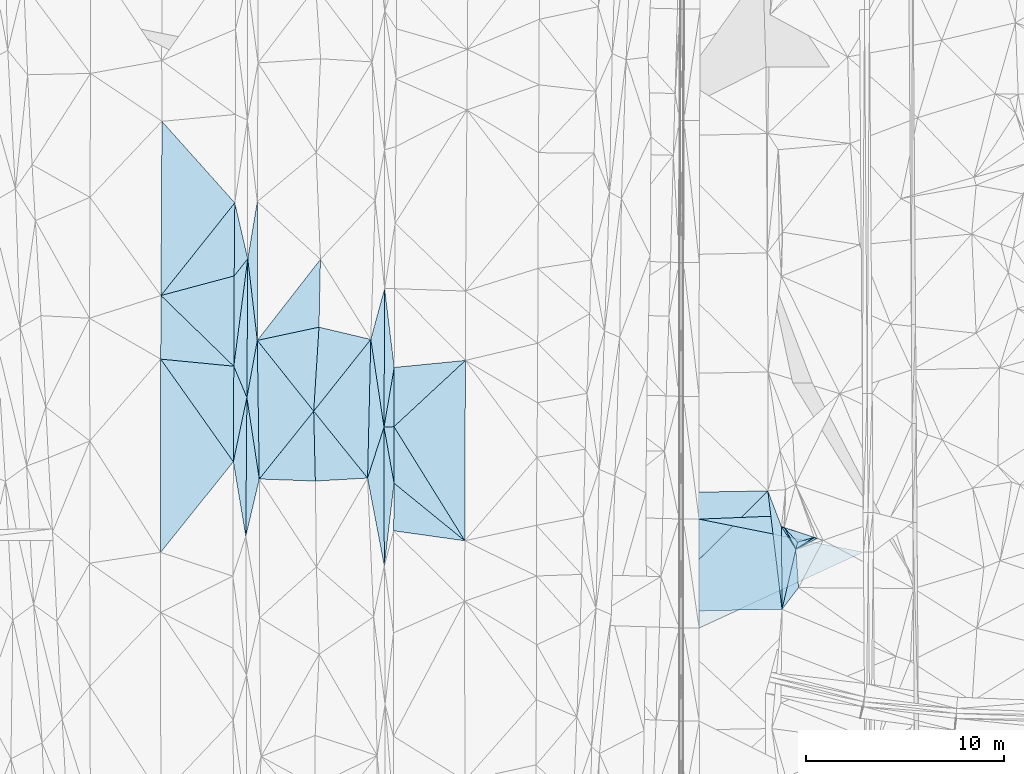
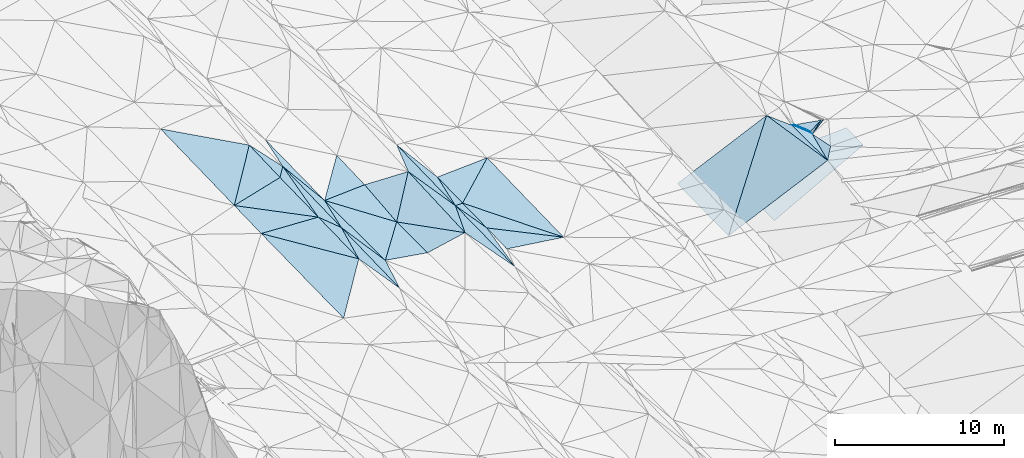
# One storey, part 111 of 275: 45 plates.
"""IFC2X3 building model written with IfcOpenShell, lengths in millimetres."""

from ifc_helpers import new_model, si_unit, frame, origin_with_axes, place, context, subcontext, project, spatial, polyline, outline, extrude, material, type_object, element, save


model = new_model("IFC2X3")

# Units and contexts
model_context = context("Model", 3, precision=1e-05, world=origin_with_axes())
body_context = subcontext(model_context, "Body", "Model", "MODEL_VIEW")
ifc_project = project(units=[si_unit("LENGTHUNIT", "METRE", prefix="MILLI"), si_unit("AREAUNIT", "SQUARE_METRE"), si_unit("VOLUMEUNIT", "CUBIC_METRE"), si_unit("MASSUNIT", "GRAM", prefix="KILO"), si_unit("TIMEUNIT", "SECOND"), si_unit("PLANEANGLEUNIT", "RADIAN"), si_unit("SOLIDANGLEUNIT", "STERADIAN"), si_unit("THERMODYNAMICTEMPERATUREUNIT", "DEGREE_CELSIUS"), si_unit("LUMINOUSINTENSITYUNIT", "LUMEN")], contexts=[model_context])

# Site, building, storey
site_placement = place(None, origin_with_axes())
site = spatial("IfcSite", under=ifc_project, at=site_placement, CompositionType="ELEMENT")
building_placement = place(site_placement, origin_with_axes())
building = spatial("IfcBuilding", under=site, at=building_placement, Name="Undefined", CompositionType="ELEMENT")
storey_placement = place(building_placement, origin_with_axes())
storey = spatial("IfcBuildingStorey", under=building, at=storey_placement, Name="Undefined", CompositionType="ELEMENT", Elevation=0.0)

# Plates
ifc_material = material()
plate_type_1 = type_object("IfcPlateType", PredefinedType="NOTDEFINED")
plate_1_placement = place(storey_placement, frame((-76061.398621355, 88579.0431568378, 42826.5059365484), z_axis=(0.153650073326919, -0.00552550848150955, -0.988109874316947), x_axis=(0.0631321634469689, 0.997996184661326, 0.00423619403960211)))
element("IfcPlate", 1, at=plate_1_placement, inside=storey, type_object=plate_type_1, material=ifc_material, Name="00", context=body_context, shape_type="SweptSolid", body=[
    extrude(outline(polyline([(0.0, 0.0), (4249.0966796875, 8.78935679793358e-09), (3798.419921875, 2680.11206054688), (0.0, 0.0)])), frame((-8.85201319254618e-08, 2.18876761149539e-07, -0.5000001331573), z_axis=(0.0, 0.0, 1.0), x_axis=(1.0, 0.0, 0.0)), (0.0, 0.0, 1.0), 1.0),
])
plate_type_2 = type_object("IfcPlateType", PredefinedType="NOTDEFINED")
plate_2_placement = place(storey_placement, frame((-48329.8620657515, 83465.6742146861, 43014.8511874444), z_axis=(0.0200807678010554, 0.0185787536200266, -0.999625726298822), x_axis=(0.0071784820166339, -0.999804238047834, -0.0184378680309524)))
element("IfcPlate", 2, at=plate_2_placement, inside=storey, type_object=plate_type_2, material=ifc_material, Name="00_PR", context=body_context, shape_type="SweptSolid", body=[
    extrude(outline(polyline([(0.0, 0.0), (2000.33972167969, 1.37588358484209e-08), (279.071472167969, 8286.1865234375), (0.0, 0.0)])), frame((-8.85201319254618e-08, 2.18876761149539e-07, -0.5000001331573), z_axis=(0.0, 0.0, 1.0), x_axis=(1.0, 0.0, 0.0)), (0.0, 0.0, 1.0), 1.0),
])
plate_type_3 = type_object("IfcPlateType", PredefinedType="NOTDEFINED")
plate_3_placement = place(storey_placement, frame((-56608.96006022, 77631.715382958, 42743.7001808371), z_axis=(0.0199500962876744, 0.0179262548293264, -0.999640256815374), x_axis=(-0.000581992991861325, 0.9998392866212, 0.0179182089776776)))
element("IfcPlate", 3, at=plate_3_placement, inside=storey, type_object=plate_type_3, material=ifc_material, Name="00_PR", context=body_context, shape_type="SweptSolid", body=[
    extrude(outline(polyline([(0.0, 0.0), (5499.43359375, -1.13941496238112e-08), (3832.76513671875, 8297.3408203125), (0.0, 0.0)])), frame((-8.85201319254618e-08, 2.18876761149539e-07, -0.5000001331573), z_axis=(0.0, 0.0, 1.0), x_axis=(1.0, 0.0, 0.0)), (0.0, 0.0, 1.0), 1.0),
])
plate_type_4 = type_object("IfcPlateType", PredefinedType="NOTDEFINED")
plate_4_placement = place(storey_placement, frame((-79389.4975679414, 96270.150412812, 43334.5002580193), z_axis=(0.026293548005733, 0.0196296631215967, -0.999461517847987), x_axis=(-0.128722748368799, -0.991417148651079, -0.022858071067959)))
element("IfcPlate", 4, at=plate_4_placement, inside=storey, type_object=plate_type_4, material=ifc_material, Name="00", context=body_context, shape_type="SweptSolid", body=[
    extrude(outline(polyline([(0.0, 0.0), (5468.52783203125, -1.86992110684514e-08), (946.277893066406, 567.939392089844), (0.0, 0.0)])), frame((-8.85201319254618e-08, 2.18876761149539e-07, -0.5000001331573), z_axis=(0.0, 0.0, 1.0), x_axis=(1.0, 0.0, 0.0)), (0.0, 0.0, 1.0), 1.0),
])
plate_type_5 = type_object("IfcPlateType", PredefinedType="NOTDEFINED")
plate_5_placement = place(storey_placement, frame((-83783.5033080834, 91207.1132388695, 43099.500396401), z_axis=(0.0356257678011647, 0.0194384997804789, -0.999176135320926), x_axis=(0.577873647541233, -0.816112554836854, 0.00472708314451159)))
element("IfcPlate", 5, at=plate_5_placement, inside=storey, type_object=plate_type_5, material=ifc_material, Name="00", context=body_context, shape_type="SweptSolid", body=[
    extrude(outline(polyline([(0.0, 0.0), (6346.408203125, 4.25570760853589e-08), (7957.20947265625, 5646.93017578125), (0.0, 0.0)])), frame((-8.85201319254618e-08, 2.18876761149539e-07, -0.5000001331573), z_axis=(0.0, 0.0, 1.0), x_axis=(1.0, 0.0, 0.0)), (0.0, 0.0, 1.0), 1.0),
])
plate_type_6 = type_object("IfcPlateType", PredefinedType="NOTDEFINED")
plate_6_placement = place(storey_placement, frame((-72005.5982954717, 84944.676149146, 43179.5001190756), z_axis=(-0.00897304242037606, 0.0210203564641131, -0.999738780444094), x_axis=(-0.176306046624745, 0.984083362593124, 0.0222736030081294)))
element("IfcPlate", 6, at=plate_6_placement, inside=storey, type_object=plate_type_6, material=ifc_material, Name="00", context=body_context, shape_type="SweptSolid", body=[
    extrude(outline(polyline([(0.0, 0.0), (2873.3564453125, 5.33327693119645e-09), (2808.68383789063, 499.494232177734), (0.0, 0.0)])), frame((-8.85201319254618e-08, 2.18876761149539e-07, -0.5000001331573), z_axis=(0.0, 0.0, 1.0), x_axis=(1.0, 0.0, 0.0)), (0.0, 0.0, 1.0), 1.0),
])
plate_type_7 = type_object("IfcPlateType", PredefinedType="NOTDEFINED")
plate_7_placement = place(storey_placement, frame((-76061.5406169814, 88579.0596890403, 42826.5044470904), z_axis=(-0.130337919078781, 0.0275417415568126, -0.991087019046376), x_axis=(0.0236364985596356, -0.999243682087104, -0.0308768480393752)))
element("IfcPlate", 7, at=plate_7_placement, inside=storey, type_object=plate_type_7, material=ifc_material, Name="00", context=body_context, shape_type="SweptSolid", body=[
    extrude(outline(polyline([(0.0, 0.0), (3530.15307617188, -7.37782102078199e-09), (3348.0322265625, 2850.384765625), (0.0, 0.0)])), frame((-8.85201319254618e-08, 2.18876761149539e-07, -0.5000001331573), z_axis=(0.0, 0.0, 1.0), x_axis=(1.0, 0.0, 0.0)), (0.0, 0.0, 1.0), 1.0),
])
plate_type_8 = type_object("IfcPlateType", PredefinedType="NOTDEFINED")
plate_8_placement = place(storey_placement, frame((-79389.5046928364, 96270.1513398641, 43334.5001404173), z_axis=(0.012046184697125, 0.0214849200903048, -0.999696597795029), x_axis=(-0.00623975140575909, -0.999748058038055, -0.0215612140551691)))
element("IfcPlate", 8, at=plate_8_placement, inside=storey, type_object=plate_type_8, material=ifc_material, Name="00", context=body_context, shape_type="SweptSolid", body=[
    extrude(outline(polyline([(0.0, 0.0), (7003.31640625, 3.29746399074793e-08), (5427.31396484375, 670.120544433594), (0.0, 0.0)])), frame((-8.85201319254618e-08, 2.18876761149539e-07, -0.5000001331573), z_axis=(0.0, 0.0, 1.0), x_axis=(1.0, 0.0, 0.0)), (0.0, 0.0, 1.0), 1.0),
])
plate_type_9 = type_object("IfcPlateType", PredefinedType="NOTDEFINED")
plate_9_placement = place(storey_placement, frame((-79433.2104893213, 89268.5973148834, 43183.5000613319), z_axis=(-0.00164496206152359, 0.0170063789564354, -0.999854027933381), x_axis=(-0.00764668241078133, -0.999826362449791, -0.0169933280592088)))
element("IfcPlate", 9, at=plate_9_placement, inside=storey, type_object=plate_type_9, material=ifc_material, Name="00", context=body_context, shape_type="SweptSolid", body=[
    extrude(outline(polyline([(0.0, 0.0), (7002.74853515625, 4.64642653241754e-08), (3246.44555664063, 658.084838867188), (0.0, 0.0)])), frame((-8.85201319254618e-08, 2.18876761149539e-07, -0.5000001331573), z_axis=(0.0, 0.0, 1.0), x_axis=(1.0, 0.0, 0.0)), (0.0, 0.0, 1.0), 1.0),
])
plate_type_10 = type_object("IfcPlateType", PredefinedType="NOTDEFINED")
plate_10_placement = place(storey_placement, frame((-51723.1854800835, 81604.5571297598, 44869.5162257406), z_axis=(-0.252757597405003, -0.000325343953163526, -0.967529581514365), x_axis=(-0.225145569483551, -0.972528379441403, 0.0591440928834538)))
element("IfcPlate", 10, at=plate_10_placement, inside=storey, type_object=plate_type_10, material=ifc_material, Name="00", context=body_context, shape_type="SweptSolid", body=[
    extrude(outline(polyline([(0.0, 0.0), (3111.04614257813, -1.9674189388752e-08), (-946.832641601563, 1001.05340576172), (0.0, 0.0)])), frame((-8.85201319254618e-08, 2.18876761149539e-07, -0.5000001331573), z_axis=(0.0, 0.0, 1.0), x_axis=(1.0, 0.0, 0.0)), (0.0, 0.0, 1.0), 1.0),
])
plate_type_11 = type_object("IfcPlateType", PredefinedType="NOTDEFINED")
plate_11_placement = place(storey_placement, frame((-80093.4344875476, 90848.5565903541, 43209.5000570496), z_axis=(0.000327801689314104, 0.0165908321142713, -0.99986230893849), x_axis=(0.385520432609089, -0.92257438894118, -0.0151819929755038)))
element("IfcPlate", 11, at=plate_11_placement, inside=storey, type_object=plate_type_11, material=ifc_material, Name="00", context=body_context, shape_type="SweptSolid", body=[
    extrude(outline(polyline([(0.0, 0.0), (1712.55505371094, -8.93487595021725e-09), (4440.0498046875, 1879.69616699219), (0.0, 0.0)])), frame((-8.85201319254618e-08, 2.18876761149539e-07, -0.5000001331573), z_axis=(0.0, 0.0, 1.0), x_axis=(1.0, 0.0, 0.0)), (0.0, 0.0, 1.0), 1.0),
])
plate_type_12 = type_object("IfcPlateType", PredefinedType="NOTDEFINED")
plate_12_placement = place(storey_placement, frame((-73342.2632609968, 85203.2659626728, 43148.5013560587), z_axis=(0.0726297184403839, 0.0134095323184575, -0.997268824561497), x_axis=(0.0233562374517354, 0.999612527194022, 0.0151420490316935)))
element("IfcPlate", 12, at=plate_12_placement, inside=storey, type_object=plate_type_12, material=ifc_material, Name="00", context=body_context, shape_type="SweptSolid", body=[
    extrude(outline(polyline([(0.0, 0.0), (7000.37353515625, 1.82772055268288e-08), (2588.86010742188, 771.899353027344), (0.0, 0.0)])), frame((-8.85201319254618e-08, 2.18876761149539e-07, -0.5000001331573), z_axis=(0.0, 0.0, 1.0), x_axis=(1.0, 0.0, 0.0)), (0.0, 0.0, 1.0), 1.0),
])
plate_type_13 = type_object("IfcPlateType", PredefinedType="NOTDEFINED")
plate_13_placement = place(storey_placement, frame((-51723.0053609567, 81604.716422007, 44869.5290448831), z_axis=(0.107479046016007, 0.31825643927385, -0.941892294016794), x_axis=(0.80539851184155, 0.527581462608026, 0.270168535243823)))
element("IfcPlate", 13, at=plate_13_placement, inside=storey, type_object=plate_type_13, material=ifc_material, Name="00", context=body_context, shape_type="SweptSolid", body=[
    extrude(outline(polyline([(0.0, 0.0), (1147.43188476563, 1.55705492943525e-09), (1244.16967773438, 130.926712036133), (0.0, 0.0)])), frame((-8.85201319254618e-08, 2.18876761149539e-07, -0.5000001331573), z_axis=(0.0, 0.0, 1.0), x_axis=(1.0, 0.0, 0.0)), (0.0, 0.0, 1.0), 1.0),
])
plate_type_14 = type_object("IfcPlateType", PredefinedType="NOTDEFINED")
plate_14_placement = place(storey_placement, frame((-50798.8081342325, 82210.1724704172, 45179.5822710436), z_axis=(0.222020974117627, 0.502739541150144, -0.835439788863328), x_axis=(-0.885869510351093, -0.253963555388073, -0.388249562993913)))
element("IfcPlate", 14, at=plate_14_placement, inside=storey, type_object=plate_type_14, material=ifc_material, Name="00", context=body_context, shape_type="SweptSolid", body=[
    extrude(outline(polyline([(0.0, 0.0), (952.995300292969, -1.29512045532465e-09), (1250.79321289063, 991.370971679688), (0.0, 0.0)])), frame((-8.85201319254618e-08, 2.18876761149539e-07, -0.5000001331573), z_axis=(0.0, 0.0, 1.0), x_axis=(1.0, 0.0, 0.0)), (0.0, 0.0, 1.0), 1.0),
])
plate_type_15 = type_object("IfcPlateType", PredefinedType="NOTDEFINED")
plate_15_placement = place(storey_placement, frame((-51722.9437625715, 81604.7063984948, 44869.5368877459), z_axis=(0.23067761607835, 0.298213137673759, -0.926205572191822), x_axis=(-0.528911314443468, 0.837400030525068, 0.137891298965157)))
element("IfcPlate", 15, at=plate_15_placement, inside=storey, type_object=plate_type_15, material=ifc_material, Name="00", context=body_context, shape_type="SweptSolid", body=[
    extrude(outline(polyline([(0.0, 0.0), (1377.89697265625, -9.69521352089942e-10), (1266.71301269531, 100.688301086426), (0.0, 0.0)])), frame((-8.85201319254618e-08, 2.18876761149539e-07, -0.5000001331573), z_axis=(0.0, 0.0, 1.0), x_axis=(1.0, 0.0, 0.0)), (0.0, 0.0, 1.0), 1.0),
])
plate_type_16 = type_object("IfcPlateType", PredefinedType="NOTDEFINED")
plate_16_placement = place(storey_placement, frame((-72512.1295597054, 87772.2972753549, 43243.5030427005), z_axis=(0.108695149794578, 0.018829851161569, -0.99389677588589), x_axis=(-0.148846257491416, 0.988857299567939, 0.00245616001151394)))
element("IfcPlate", 16, at=plate_16_placement, inside=storey, type_object=plate_type_16, material=ifc_material, Name="00", context=body_context, shape_type="SweptSolid", body=[
    extrude(outline(polyline([(0.0, 0.0), (4478.53564453125, -8.30914359539747e-09), (6914.90185546875, 1079.14953613281), (0.0, 0.0)])), frame((-8.85201319254618e-08, 2.18876761149539e-07, -0.5000001331573), z_axis=(0.0, 0.0, 1.0), x_axis=(1.0, 0.0, 0.0)), (0.0, 0.0, 1.0), 1.0),
])
plate_type_17 = type_object("IfcPlateType", PredefinedType="NOTDEFINED")
plate_17_placement = place(storey_placement, frame((-79486.7734866413, 82267.0649761344, 43064.500320727), z_axis=(-0.0320753015141071, 0.0172303216631153, -0.999336925690312), x_axis=(0.00764668246942341, 0.999826362449911, 0.016993328025735)))
element("IfcPlate", 17, at=plate_17_placement, inside=storey, type_object=plate_type_17, material=ifc_material, Name="00", context=body_context, shape_type="SweptSolid", body=[
    extrude(outline(polyline([(0.0, 0.0), (7002.74853515625, 4.64642653241754e-08), (2893.41333007813, 657.383361816406), (0.0, 0.0)])), frame((-8.85201319254618e-08, 2.18876761149539e-07, -0.5000001331573), z_axis=(0.0, 0.0, 1.0), x_axis=(1.0, 0.0, 0.0)), (0.0, 0.0, 1.0), 1.0),
])
plate_type_18 = type_object("IfcPlateType", PredefinedType="NOTDEFINED")
plate_18_placement = place(storey_placement, frame((-68436.269946508, 82039.8649116986, 43019.500291198), z_axis=(-0.0276908734220919, 0.0210220872404197, -0.99939546095486), x_axis=(-0.989922918560391, 0.138319287382846, 0.0303379308256113)))
element("IfcPlate", 18, at=plate_18_placement, inside=storey, type_object=plate_type_18, material=ifc_material, Name="00", context=body_context, shape_type="SweptSolid", body=[
    extrude(outline(polyline([(0.0, 0.0), (3625.82397460938, 5.34055288881063e-09), (3940.0146484375, 2383.27172851563), (0.0, 0.0)])), frame((-8.85201319254618e-08, 2.18876761149539e-07, -0.5000001331573), z_axis=(0.0, 0.0, 1.0), x_axis=(1.0, 0.0, 0.0)), (0.0, 0.0, 1.0), 1.0),
])
plate_type_19 = type_object("IfcPlateType", PredefinedType="NOTDEFINED")
plate_19_placement = place(storey_placement, frame((-68436.269946508, 82039.8649116986, 43019.500291198), z_axis=(-0.0277170835757687, 0.0209898774193891, -0.999395411398298), x_axis=(-0.775142973463073, 0.630829639659116, 0.0347467468747148)))
element("IfcPlate", 19, at=plate_19_placement, inside=storey, type_object=plate_type_19, material=ifc_material, Name="00", context=body_context, shape_type="SweptSolid", body=[
    extrude(outline(polyline([(0.0, 0.0), (4604.74755859375, 2.76450009550899e-08), (6408.77685546875, 2209.90454101563), (0.0, 0.0)])), frame((-8.85201319254618e-08, 2.18876761149539e-07, -0.5000001331573), z_axis=(0.0, 0.0, 1.0), x_axis=(1.0, 0.0, 0.0)), (0.0, 0.0, 1.0), 1.0),
])
plate_type_20 = type_object("IfcPlateType", PredefinedType="NOTDEFINED")
plate_20_placement = place(storey_placement, frame((-52311.016542431, 82711.397692289, 45079.5486156422), z_axis=(-0.426603078991157, -0.0552514056152115, -0.902749741164631), x_axis=(0.644994158429637, -0.718294557505941, -0.260836086937733)))
element("IfcPlate", 20, at=plate_20_placement, inside=storey, type_object=plate_type_20, material=ifc_material, Name="00", context=body_context, shape_type="SweptSolid", body=[
    extrude(outline(polyline([(0.0, 0.0), (1035.1328125, -4.8712536226958e-09), (1228.92443847656, 323.179260253906), (0.0, 0.0)])), frame((-8.85201319254618e-08, 2.18876761149539e-07, -0.5000001331573), z_axis=(0.0, 0.0, 1.0), x_axis=(1.0, 0.0, 0.0)), (0.0, 0.0, 1.0), 1.0),
])
plate_type_21 = type_object("IfcPlateType", PredefinedType="NOTDEFINED")
plate_21_placement = place(storey_placement, frame((-79389.5004629837, 96270.1527140369, 43334.5002371914), z_axis=(0.0205020702365341, 0.0242175538929406, -0.999496460823878), x_axis=(-0.620520093969136, -0.78354901782711, -0.0317135561346526)))
element("IfcPlate", 21, at=plate_21_placement, inside=storey, type_object=plate_type_21, material=ifc_material, Name="00", context=body_context, shape_type="SweptSolid", body=[
    extrude(outline(polyline([(0.0, 0.0), (1103.62902832031, 1.04773789644241e-09), (-1808.31872558594, 2264.65454101563), (0.0, 0.0)])), frame((-8.85201319254618e-08, 2.18876761149539e-07, -0.5000001331573), z_axis=(0.0, 0.0, 1.0), x_axis=(1.0, 0.0, 0.0)), (0.0, 0.0, 1.0), 1.0),
])
plate_type_22 = type_object("IfcPlateType", PredefinedType="NOTDEFINED")
plate_22_placement = place(storey_placement, frame((-71997.1741087406, 90786.9722400714, 43299.5001091481), z_axis=(-0.0089282110984341, 0.0200965703869923, -0.999758178213743), x_axis=(-0.00399983529831744, -0.999790746772904, -0.0200615050498691)))
element("IfcPlate", 22, at=plate_22_placement, inside=storey, type_object=plate_type_22, material=ifc_material, Name="00", context=body_context, shape_type="SweptSolid", body=[
    extrude(outline(polyline([(0.0, 0.0), (2990.80249023438, -8.62928573042154e-09), (3017.22680664063, 502.969940185547), (0.0, 0.0)])), frame((-8.85201319254618e-08, 2.18876761149539e-07, -0.5000001331573), z_axis=(0.0, 0.0, 1.0), x_axis=(1.0, 0.0, 0.0)), (0.0, 0.0, 1.0), 1.0),
])
plate_type_23 = type_object("IfcPlateType", PredefinedType="NOTDEFINED")
plate_23_placement = place(storey_placement, frame((-78807.6287037125, 85155.3098900909, 43092.5005360979), z_axis=(-0.0443328096964054, 0.0153563438803715, -0.998898786007396), x_axis=(-0.150328102558898, 0.988394309133004, 0.0218666699461303)))
element("IfcPlate", 23, at=plate_23_placement, inside=storey, type_object=plate_type_23, material=ifc_material, Name="00", context=body_context, shape_type="SweptSolid", body=[
    extrude(outline(polyline([(0.0, 0.0), (4161.58447265625, 5.58793544769287e-09), (6932.177734375, 953.597351074219), (0.0, 0.0)])), frame((-8.85201319254618e-08, 2.18876761149539e-07, -0.5000001331573), z_axis=(0.0, 0.0, 1.0), x_axis=(1.0, 0.0, 0.0)), (0.0, 0.0, 1.0), 1.0),
])
plate_type_24 = type_object("IfcPlateType", PredefinedType="NOTDEFINED")
plate_24_placement = place(storey_placement, frame((-51722.8357781837, 81604.4370215083, 44869.5691055022), z_axis=(0.446646440680531, -0.240541780200389, -0.861769463955088), x_axis=(0.212060438423732, 0.964198246077183, -0.15922346785954)))
element("IfcPlate", 24, at=plate_24_placement, inside=storey, type_object=plate_type_24, material=ifc_material, Name="00", context=body_context, shape_type="SweptSolid", body=[
    extrude(outline(polyline([(0.0, 0.0), (376.828887939453, 2.3283064365387e-10), (730.304992675781, 885.016723632813), (0.0, 0.0)])), frame((-8.85201319254618e-08, 2.18876761149539e-07, -0.5000001331573), z_axis=(0.0, 0.0, 1.0), x_axis=(1.0, 0.0, 0.0)), (0.0, 0.0, 1.0), 1.0),
])
plate_type_25 = type_object("IfcPlateType", PredefinedType="NOTDEFINED")
plate_25_placement = place(storey_placement, frame((-51722.9404312582, 81604.5004840544, 44869.5176113387), z_axis=(0.23733966066292, -0.113617047970673, -0.964759582428099), x_axis=(0.0677114735937339, -0.988786334078423, 0.133104251936288)))
element("IfcPlate", 25, at=plate_25_placement, inside=storey, type_object=plate_type_25, material=ifc_material, Name="00", context=body_context, shape_type="SweptSolid", body=[
    extrude(outline(polyline([(0.0, 0.0), (1953.35607910156, -1.53886503539979e-09), (2968.71630859375, 930.232055664063), (0.0, 0.0)])), frame((-8.85201319254618e-08, 2.18876761149539e-07, -0.5000001331573), z_axis=(0.0, 0.0, 1.0), x_axis=(1.0, 0.0, 0.0)), (0.0, 0.0, 1.0), 1.0),
])
plate_type_26 = type_object("IfcPlateType", PredefinedType="NOTDEFINED")
plate_26_placement = place(storey_placement, frame((-72512.186503279, 87772.2975943115, 43243.5000896714), z_axis=(-0.00517193972132726, 0.0194555926054657, -0.999797344943409), x_axis=(0.00448728430822682, 0.999801102243788, 0.0194324530526691)))
element("IfcPlate", 26, at=plate_26_placement, inside=storey, type_object=plate_type_26, material=ifc_material, Name="00", context=body_context, shape_type="SweptSolid", body=[
    extrude(outline(polyline([(0.0, 0.0), (6998.60205078125, -1.56724127009511e-08), (3017.47387695313, 501.485778808594), (0.0, 0.0)])), frame((-8.85201319254618e-08, 2.18876761149539e-07, -0.5000001331573), z_axis=(0.0, 0.0, 1.0), x_axis=(1.0, 0.0, 0.0)), (0.0, 0.0, 1.0), 1.0),
])
plate_27_placement = place(storey_placement, frame((-72497.600713148, 80772.4601989275, 43090.5001123909), z_axis=(-0.00438245375946642, 0.0218430903651201, -0.999751805951031), x_axis=(-0.00208317368745595, 0.999759037905374, 0.0218523800513554)))
element("IfcPlate", 27, at=plate_27_placement, inside=storey, type_object=plate_type_26, material=ifc_material, Name="00", context=body_context, shape_type="SweptSolid", body=[
    extrude(outline(polyline([(0.0, 0.0), (7001.52587890625, -4.8748916015029e-08), (4172.130859375, 500.701873779297), (0.0, 0.0)])), frame((-8.85201319254618e-08, 2.18876761149539e-07, -0.5000001331573), z_axis=(0.0, 0.0, 1.0), x_axis=(1.0, 0.0, 0.0)), (0.0, 0.0, 1.0), 1.0),
])
plate_type_27 = type_object("IfcPlateType", PredefinedType="NOTDEFINED")
plate_28_placement = place(storey_placement, frame((-52423.3997425402, 78578.9780124086, 45053.5096130217), z_axis=(0.195220995714794, 0.00273206287679033, -0.980755473430845), x_axis=(-0.118991679633738, 0.992674833169899, -0.0209202239245961)))
element("IfcPlate", 28, at=plate_28_placement, inside=storey, type_object=plate_type_27, material=ifc_material, Name="00", context=body_context, shape_type="SweptSolid", body=[
    extrude(outline(polyline([(0.0, 0.0), (6022.8798828125, -4.02869773097336e-08), (4152.06396484375, 478.384490966797), (0.0, 0.0)])), frame((-8.85201319254618e-08, 2.18876761149539e-07, -0.5000001331573), z_axis=(0.0, 0.0, 1.0), x_axis=(1.0, 0.0, 0.0)), (0.0, 0.0, 1.0), 1.0),
])
plate_type_28 = type_object("IfcPlateType", PredefinedType="NOTDEFINED")
plate_29_placement = place(storey_placement, frame((-75720.5640668157, 96241.2140744895, 42872.5034568985), z_axis=(-0.117058811920106, 0.0106143555435703, -0.993068260497861), x_axis=(-0.0212464344409121, -0.999740794639203, -0.008181232041841)))
element("IfcPlate", 29, at=plate_29_placement, inside=storey, type_object=plate_type_28, material=ifc_material, Name="00", context=body_context, shape_type="SweptSolid", body=[
    extrude(outline(polyline([(0.0, 0.0), (3422.46752929688, -2.16678017750382e-08), (4154.0068359375, 3121.30029296875), (0.0, 0.0)])), frame((-8.85201319254618e-08, 2.18876761149539e-07, -0.5000001331573), z_axis=(0.0, 0.0, 1.0), x_axis=(1.0, 0.0, 0.0)), (0.0, 0.0, 1.0), 1.0),
])
plate_type_29 = type_object("IfcPlateType", PredefinedType="NOTDEFINED")
plate_30_placement = place(storey_placement, frame((-78907.9473484061, 92151.1557235566, 43204.5028093221), z_axis=(-0.104382736417841, 0.0191778467395598, -0.994352278889307), x_axis=(-0.11607732359135, 0.992745864358552, 0.0313321519666298)))
element("IfcPlate", 30, at=plate_30_placement, inside=storey, type_object=plate_type_29, material=ifc_material, Name="00", context=body_context, shape_type="SweptSolid", body=[
    extrude(outline(polyline([(0.0, 0.0), (4149.0927734375, 2.07801349461079e-08), (6954.3427734375, 817.5048828125), (0.0, 0.0)])), frame((-8.85201319254618e-08, 2.18876761149539e-07, -0.5000001331573), z_axis=(0.0, 0.0, 1.0), x_axis=(1.0, 0.0, 0.0)), (0.0, 0.0, 1.0), 1.0),
])
plate_type_30 = type_object("IfcPlateType", PredefinedType="NOTDEFINED")
plate_31_placement = place(storey_placement, frame((-79433.2500868543, 89268.5998064257, 43183.5017477198), z_axis=(-0.0808602377076193, 0.0219954666655553, -0.996482725090622), x_axis=(0.00623975146450022, 0.999748058038555, 0.0215612140149553)))
element("IfcPlate", 31, at=plate_31_placement, inside=storey, type_object=plate_type_30, material=ifc_material, Name="00", context=body_context, shape_type="SweptSolid", body=[
    extrude(outline(polyline([(0.0, 0.0), (7003.31640625, 3.29746399074793e-08), (2885.56176757813, 508.985961914063), (0.0, 0.0)])), frame((-8.85201319254618e-08, 2.18876761149539e-07, -0.5000001331573), z_axis=(0.0, 0.0, 1.0), x_axis=(1.0, 0.0, 0.0)), (0.0, 0.0, 1.0), 1.0),
])
plate_type_31 = type_object("IfcPlateType", PredefinedType="NOTDEFINED")
plate_32_placement = place(storey_placement, frame((-83720.3455717189, 103207.389100483, 43349.5003726917), z_axis=(0.0335454246165404, 0.0202704047957367, -0.999231612378588), x_axis=(0.666416687326389, -0.745544271500233, 0.00724831608781758)))
element("IfcPlate", 32, at=plate_32_placement, inside=storey, type_object=plate_type_31, material=ifc_material, Name="00", context=body_context, shape_type="SweptSolid", body=[
    extrude(outline(polyline([(0.0, 0.0), (5518.5234375, -4.18367562815547e-09), (6519.46142578125, 5899.951171875), (0.0, 0.0)])), frame((-8.85201319254618e-08, 2.18876761149539e-07, -0.5000001331573), z_axis=(0.0, 0.0, 1.0), x_axis=(1.0, 0.0, 0.0)), (0.0, 0.0, 1.0), 1.0),
])
plate_type_32 = type_object("IfcPlateType", PredefinedType="NOTDEFINED")
plate_33_placement = place(storey_placement, frame((-80042.7119487684, 99093.0875635179, 43389.5003376912), z_axis=(0.0286912464740978, 0.0241424864670762, -0.999296729066472), x_axis=(-0.00856847946441811, -0.999665617818044, -0.0243974119967059)))
element("IfcPlate", 33, at=plate_33_placement, inside=storey, type_object=plate_type_32, material=ifc_material, Name="00", context=body_context, shape_type="SweptSolid", body=[
    extrude(outline(polyline([(0.0, 0.0), (3688.91577148438, 1.98633642867208e-08), (4712.224609375, 3688.66357421875), (0.0, 0.0)])), frame((-8.85201319254618e-08, 2.18876761149539e-07, -0.5000001331573), z_axis=(0.0, 0.0, 1.0), x_axis=(1.0, 0.0, 0.0)), (0.0, 0.0, 1.0), 1.0),
])
plate_type_33 = type_object("IfcPlateType", PredefinedType="NOTDEFINED")
plate_34_placement = place(storey_placement, frame((-75977.9553073585, 85051.5798508674, 42717.5066776122), z_axis=(0.159363108799739, 0.0342565805335878, -0.986625504557747), x_axis=(-0.0236364985488772, 0.999243682087289, 0.0308768480416162)))
element("IfcPlate", 34, at=plate_34_placement, inside=storey, type_object=plate_type_33, material=ifc_material, Name="00", context=body_context, shape_type="SweptSolid", body=[
    extrude(outline(polyline([(0.0, 0.0), (3530.15307617188, -7.37782102078199e-09), (102.59016418457, 2673.07861328125), (0.0, 0.0)])), frame((-8.85201319254618e-08, 2.18876761149539e-07, -0.5000001331573), z_axis=(0.0, 0.0, 1.0), x_axis=(1.0, 0.0, 0.0)), (0.0, 0.0, 1.0), 1.0),
])
plate_type_34 = type_object("IfcPlateType", PredefinedType="NOTDEFINED")
plate_35_placement = place(storey_placement, frame((-68403.170938424, 91140.3647132995, 43219.5002374326), z_axis=(-0.0242297719650733, 0.0201526721420706, -0.999503270607983), x_axis=(-0.73327747639678, -0.679917349388602, 0.00406701482008312)))
element("IfcPlate", 35, at=plate_35_placement, inside=storey, type_object=plate_type_34, material=ifc_material, Name="00", context=body_context, shape_type="SweptSolid", body=[
    extrude(outline(polyline([(0.0, 0.0), (4917.611328125, 3.92901711165905e-10), (2876.01025390625, 2185.58129882813), (0.0, 0.0)])), frame((-8.85201319254618e-08, 2.18876761149539e-07, -0.5000001331573), z_axis=(0.0, 0.0, 1.0), x_axis=(1.0, 0.0, 0.0)), (0.0, 0.0, 1.0), 1.0),
])
plate_type_35 = type_object("IfcPlateType", PredefinedType="NOTDEFINED")
plate_36_placement = place(storey_placement, frame((-72009.145360637, 87796.7964897736, 43239.50027898), z_axis=(-0.0259965220694428, 0.0220585836301395, -0.999418630869229), x_axis=(0.733277476396196, 0.679917349389222, -0.00406701482194591)))
element("IfcPlate", 36, at=plate_36_placement, inside=storey, type_object=plate_type_35, material=ifc_material, Name="00", context=body_context, shape_type="SweptSolid", body=[
    extrude(outline(polyline([(0.0, 0.0), (4917.611328125, 3.92901711165905e-10), (-1293.43286132813, 6654.55712890625), (0.0, 0.0)])), frame((-8.85201319254618e-08, 2.18876761149539e-07, -0.5000001331573), z_axis=(0.0, 0.0, 1.0), x_axis=(1.0, 0.0, 0.0)), (0.0, 0.0, 1.0), 1.0),
])
plate_type_36 = type_object("IfcPlateType", PredefinedType="NOTDEFINED")
plate_37_placement = place(storey_placement, frame((-83783.5054301355, 91207.111732016, 43099.5003007604), z_axis=(0.0313879880786636, 0.0164366740992365, -0.999372117856472), x_axis=(0.994874640558567, -0.0966691413399122, 0.0296568151706394)))
element("IfcPlate", 37, at=plate_37_placement, inside=storey, type_object=plate_type_36, material=ifc_material, Name="00", context=body_context, shape_type="SweptSolid", body=[
    extrude(outline(polyline([(0.0, 0.0), (3709.09692382813, 2.34722392633557e-08), (4150.20166015625, 4801.32568359375), (0.0, 0.0)])), frame((-8.85201319254618e-08, 2.18876761149539e-07, -0.5000001331573), z_axis=(0.0, 0.0, 1.0), x_axis=(1.0, 0.0, 0.0)), (0.0, 0.0, 1.0), 1.0),
])
plate_type_37 = type_object("IfcPlateType", PredefinedType="NOTDEFINED")
plate_38_placement = place(storey_placement, frame((-72497.5752964321, 80772.4602443451, 43090.5006463001), z_axis=(0.0464360021942326, 0.0219255656751297, -0.998680613244316), x_axis=(-0.187254352471764, 0.982227311735216, 0.0128575099374206)))
element("IfcPlate", 38, at=plate_38_placement, inside=storey, type_object=plate_type_37, material=ifc_material, Name="00", context=body_context, shape_type="SweptSolid", body=[
    extrude(outline(polyline([(0.0, 0.0), (4510.982421875, -7.32688931748271e-09), (6880.130859375, 1298.13684082031), (0.0, 0.0)])), frame((-8.85201319254618e-08, 2.18876761149539e-07, -0.5000001331573), z_axis=(0.0, 0.0, 1.0), x_axis=(1.0, 0.0, 0.0)), (0.0, 0.0, 1.0), 1.0),
])
plate_type_38 = type_object("IfcPlateType", PredefinedType="NOTDEFINED")
plate_39_placement = place(storey_placement, frame((-80074.3197434333, 95405.4029773239, 43299.5003076176), z_axis=(0.0299054677220652, 0.0196125247350326, -0.999360301329727), x_axis=(-0.00419063338464982, -0.9997962367393, -0.0197464830734263)))
element("IfcPlate", 39, at=plate_39_placement, inside=storey, type_object=plate_type_38, material=ifc_material, Name="00", context=body_context, shape_type="SweptSolid", body=[
    extrude(outline(polyline([(0.0, 0.0), (4557.7734375, 1.30239641293883e-08), (1006.65380859375, 3693.24365234375), (0.0, 0.0)])), frame((-8.85201319254618e-08, 2.18876761149539e-07, -0.5000001331573), z_axis=(0.0, 0.0, 1.0), x_axis=(1.0, 0.0, 0.0)), (0.0, 0.0, 1.0), 1.0),
])
plate_type_39 = type_object("IfcPlateType", PredefinedType="NOTDEFINED")
plate_40_placement = place(storey_placement, frame((-83770.0965322265, 94416.6034299336, 43169.5003595849), z_axis=(0.031892163536762, 0.0216608712561501, -0.999256571938043), x_axis=(0.717607197678647, -0.69640430686617, 0.00780712610689945)))
element("IfcPlate", 40, at=plate_40_placement, inside=storey, type_object=plate_type_39, material=ifc_material, Name="00", context=body_context, shape_type="SweptSolid", body=[
    extrude(outline(polyline([(0.0, 0.0), (5123.5244140625, -4.67298377770931e-09), (2224.93334960938, 2314.21069335938), (0.0, 0.0)])), frame((-8.85201319254618e-08, 2.18876761149539e-07, -0.5000001331573), z_axis=(0.0, 0.0, 1.0), x_axis=(1.0, 0.0, 0.0)), (0.0, 0.0, 1.0), 1.0),
])
plate_type_40 = type_object("IfcPlateType", PredefinedType="NOTDEFINED")
plate_41_placement = place(storey_placement, frame((-73178.731096699, 92200.9265413041, 43254.5044148937), z_axis=(0.132176082828395, 0.0119255950541523, -0.991154510311458), x_axis=(-0.0233562374699285, -0.999612527193664, -0.0151420490272887)))
element("IfcPlate", 41, at=plate_41_placement, inside=storey, type_object=plate_type_40, material=ifc_material, Name="00", context=body_context, shape_type="SweptSolid", body=[
    extrude(outline(polyline([(0.0, 0.0), (7000.37353515625, 1.82772055268288e-08), (3694.28051757813, 2821.92919921875), (0.0, 0.0)])), frame((-8.85201319254618e-08, 2.18876761149539e-07, -0.5000001331573), z_axis=(0.0, 0.0, 1.0), x_axis=(1.0, 0.0, 0.0)), (0.0, 0.0, 1.0), 1.0),
])
plate_type_41 = type_object("IfcPlateType", PredefinedType="NOTDEFINED")
plate_42_placement = place(storey_placement, frame((-76061.5324518146, 88579.0530555381, 42826.5033014262), z_axis=(-0.114011984441313, 0.0142690581909448, -0.993376897950671), x_axis=(-0.624540003349514, -0.778646338030666, 0.0604951608612113)))
element("IfcPlate", 42, at=plate_42_placement, inside=storey, type_object=plate_type_41, material=ifc_material, Name="00", context=body_context, shape_type="SweptSolid", body=[
    extrude(outline(polyline([(0.0, 0.0), (4397.0458984375, 3.20142135024071e-08), (-980.832580566406, 4476.9248046875), (0.0, 0.0)])), frame((-8.85201319254618e-08, 2.18876761149539e-07, -0.5000001331573), z_axis=(0.0, 0.0, 1.0), x_axis=(1.0, 0.0, 0.0)), (0.0, 0.0, 1.0), 1.0),
])
plate_type_42 = type_object("IfcPlateType", PredefinedType="NOTDEFINED")
plate_43_placement = place(storey_placement, frame((-78907.9537893026, 92151.1519388674, 43204.5034744666), z_axis=(-0.117273342823894, 0.0116337063334749, -0.993031530184141), x_axis=(0.971550594449097, 0.208517563663793, -0.112293668874616)))
element("IfcPlate", 43, at=plate_43_placement, inside=storey, type_object=plate_type_42, material=ifc_material, Name="00", context=body_context, shape_type="SweptSolid", body=[
    extrude(outline(polyline([(0.0, 0.0), (3205.87963867188, -6.88305590301752e-09), (2063.04223632813, 4092.52319335938), (0.0, 0.0)])), frame((-8.85201319254618e-08, 2.18876761149539e-07, -0.5000001331573), z_axis=(0.0, 0.0, 1.0), x_axis=(1.0, 0.0, 0.0)), (0.0, 0.0, 1.0), 1.0),
])
plate_type_43 = type_object("IfcPlateType", PredefinedType="NOTDEFINED")
plate_44_placement = place(storey_placement, frame((-59264.149313788, 78452.0985989242, 42079.542153793), z_axis=(0.401154059538701, 0.0247485839532797, -0.91567621357548), x_axis=(-0.0053203405623746, 0.999681042066975, 0.0246882180035008)))
element("IfcPlate", 44, at=plate_44_placement, inside=storey, type_object=plate_type_43, material=ifc_material, Name="00", context=body_context, shape_type="SweptSolid", body=[
    extrude(outline(polyline([(0.0, 0.0), (5994.76220703125, 3.98722477257252e-08), (6141.43359375, 6721.4921875), (0.0, 0.0)])), frame((-8.85201319254618e-08, 2.18876761149539e-07, -0.5000001331573), z_axis=(0.0, 0.0, 1.0), x_axis=(1.0, 0.0, 0.0)), (0.0, 0.0, 1.0), 1.0),
])
plate_type_44 = type_object("IfcPlateType", PredefinedType="NOTDEFINED")
plate_45_placement = place(storey_placement, frame((-53139.9709645037, 84557.7522939158, 44927.5415398018), z_axis=(0.39809032937386, 0.028395546756438, -0.916906637877278), x_axis=(0.118991679572512, -0.992674833175122, 0.0209202240250047)))
element("IfcPlate", 45, at=plate_45_placement, inside=storey, type_object=plate_type_44, material=ifc_material, Name="00", context=body_context, shape_type="SweptSolid", body=[
    extrude(outline(polyline([(0.0, 0.0), (6022.8798828125, -4.02869773097336e-08), (5272.61962890625, 7422.61083984375), (0.0, 0.0)])), frame((-8.85201319254618e-08, 2.18876761149539e-07, -0.5000001331573), z_axis=(0.0, 0.0, 1.0), x_axis=(1.0, 0.0, 0.0)), (0.0, 0.0, 1.0), 1.0),
])

save(model, "model.ifc")
